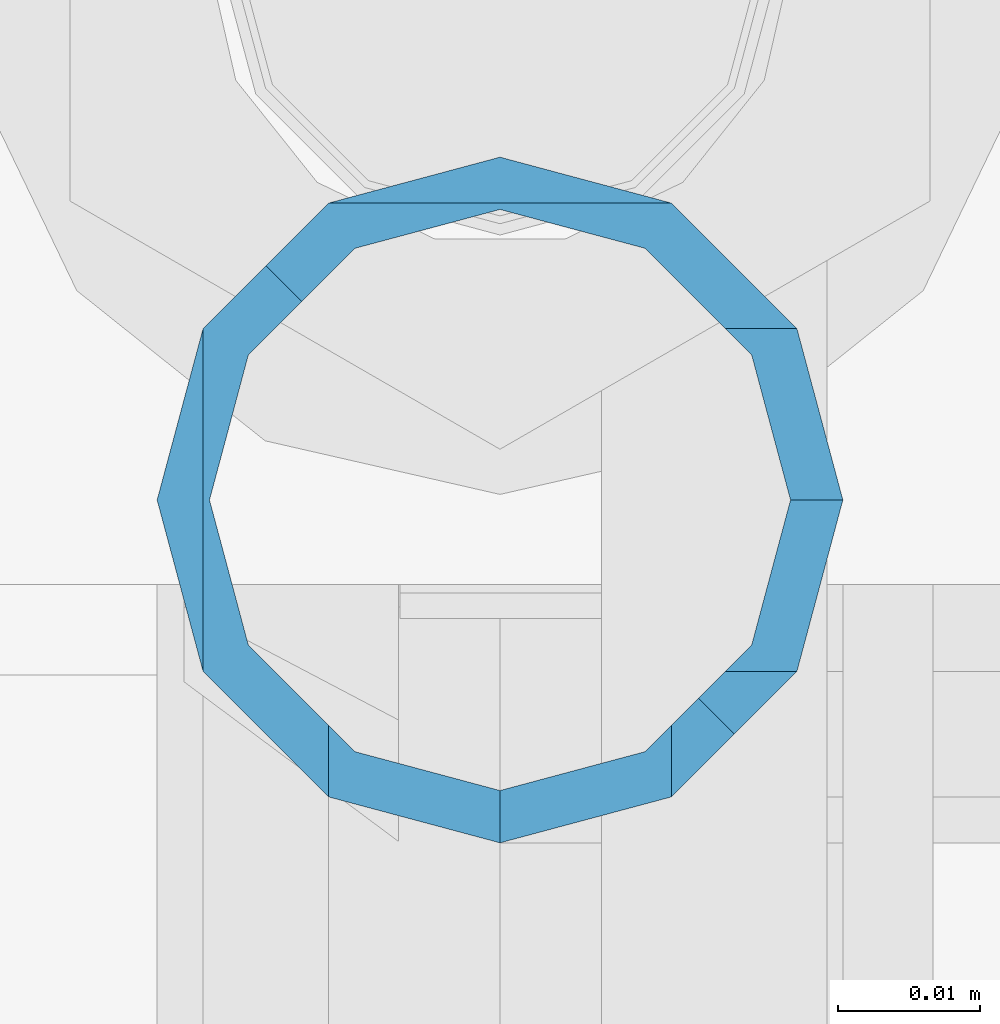
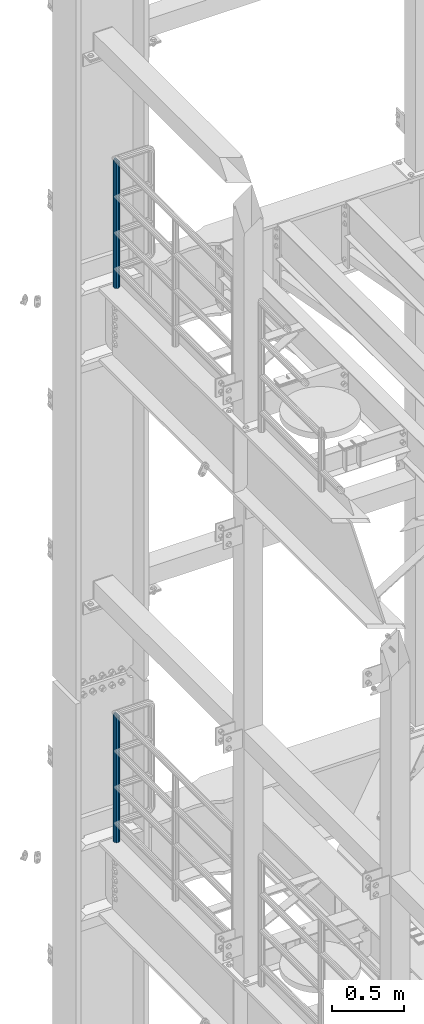
# One storey, part 747 of 1876: 2 columns, 2 elements without a shape of their own.
"""IFC2X3 building model written with IfcOpenShell, lengths in millimetres."""

from ifc_helpers import new_model, si_unit, frame, origin_with_axes, place, context, subcontext, project, spatial, faceted_brep, material, type_object, element, aggregate, save


model = new_model("IFC2X3")

# Units and contexts
model_context = context("Model", 3, precision=1e-05, world=origin_with_axes())
body_context = subcontext(model_context, "Body", "Model", "MODEL_VIEW")
ifc_project = project(units=[si_unit("LENGTHUNIT", "METRE", prefix="MILLI"), si_unit("AREAUNIT", "SQUARE_METRE"), si_unit("VOLUMEUNIT", "CUBIC_METRE"), si_unit("MASSUNIT", "GRAM", prefix="KILO"), si_unit("TIMEUNIT", "SECOND"), si_unit("PLANEANGLEUNIT", "RADIAN"), si_unit("SOLIDANGLEUNIT", "STERADIAN"), si_unit("THERMODYNAMICTEMPERATUREUNIT", "DEGREE_CELSIUS"), si_unit("LUMINOUSINTENSITYUNIT", "LUMEN")], contexts=[model_context])

# Site, building, storey
site_placement = place(None, origin_with_axes())
site = spatial("IfcSite", under=ifc_project, at=site_placement, CompositionType="ELEMENT")
building_placement = place(site_placement, origin_with_axes())
building = spatial("IfcBuilding", under=site, at=building_placement, Name="Undefined", CompositionType="ELEMENT")
storey_placement = place(building_placement, origin_with_axes())
storey = spatial("IfcBuildingStorey", under=building, at=storey_placement, Name="Undefined", CompositionType="ELEMENT", Elevation=0.0)

# Assembly, column
assembly_1_placement = place(storey_placement, origin_with_axes())
assembly_1 = element("IfcElementAssembly", 1, at=assembly_1_placement, inside=storey, Name="RAIL", AssemblyPlace="NOTDEFINED", PredefinedType="RIGID_FRAME")
ifc_material = material()
column_type = type_object("IfcColumnType", Name="PIPE1-1/2SCH40", PredefinedType="NOTDEFINED")
column_1_placement = place(assembly_1_placement, frame((-1.81898940354586e-12, 13499.7063, 17983.2), z_axis=(0.0, 1.0, 0.0), x_axis=(0.0, 0.0, 1.0)))
column_1 = element("IfcColumn", 2, at=column_1_placement, type_object=column_type, material=ifc_material, Name="POST", ObjectType="PIPE1-1/2SCH40", context=body_context, shape_type="Brep", body=[
    faceted_brep([(1076.325, -24.1300000000001, 0.0), (1064.25999999999, -20.8971929933186, -12.0649999999996), (1064.26, -20.8971929933184, 12.0649999999996), (1054.93437856882, 17.7076214311801, 10.2235000000001), (1052.195, 20.4470000000001, 0.0), (1052.195, 24.13, 0.0), (1055.42780700668, 20.8971929933185, 12.0649999999996), (1055.42780700668, 15.8661214311869, 12.0649999999932), (1055.42780700668, 15.8661214311742, -12.065000000006), (1055.42780700668, 20.8971929933185, -12.0649999999996), (1054.93437856882, 17.7076214311801, -10.2235000000001), (1057.32837749232, 13.9655704718316, -13.9655509593485), (1059.84391327712, 16.4811062541432, -16.4810867391752), (1055.42780700668, 12.0650000000001, -15.8661214311805), (1055.42780700667, 12.0649999999996, -20.8971929933186), (1054.93437856882, 10.2235000000001, -17.7076214311801), (1052.195, 0.0, -20.4470000000001), (1052.19499999999, 0.0, -24.1300000000001), (1055.42780700668, -12.0650000000001, -15.8661214311805), (1055.42780700667, -12.0649999999996, -20.8971929933186), (1054.93437856882, -10.2235000000001, -17.7076214311801), (1061.07042843786, -17.7076214311803, -10.2235000000001), (1063.80980700668, -20.4469999999999, 0.0), (1061.07042843786, -17.7076214311803, 10.2235000000001), (1057.32835795223, -13.9655509593467, 13.9655704718334), (1059.84389372957, -16.4810867391727, 16.4811062541457), (1076.325, 0.0, 24.1300000000001), (1064.26, -12.0650000000001, 20.8971929933186), (1064.26, 12.065, 20.8971929933186), (1061.07042843787, -10.2235000000001, 17.7076214311801), (1063.80980700669, 0.0, 20.4470000000001), (1061.07042843787, 10.2235000000001, 17.7076214311801), (0.0, -20.8971929933184, -12.0649999999996), (0.0, -12.0650000000001, -20.8971929933186), (-1.45519152283669e-11, 0.0, -24.130000000001), (0.0, 12.0650000000001, -20.8971929933186), (0.0, 20.8971929933184, -12.0649999999996), (0.0, 24.1299999999992, 0.0), (0.0, 20.8971929933184, 12.0649999999996), (0.0, 12.0650000000001, 20.8971929933186), (-1.45519152283669e-11, 0.0, 24.130000000001), (0.0, -20.8971929933184, 12.0649999999996), (0.0, -24.1299999999992, 0.0), (0.0, -12.0650000000001, 20.8971929933186), (0.0, -17.7076214311803, -10.2235000000001), (0.0, -10.2235000000001, -17.7076214311801), (-1.45519152283669e-11, 0.0, -20.4470000000001), (0.0, 10.2235000000001, -17.7076214311801), (0.0, 17.7076214311803, -10.2235000000001), (0.0, 20.4469999999999, 0.0), (0.0, 17.7076214311803, 10.2235000000001), (0.0, 10.2235000000001, 17.7076214311801), (-1.45519152283669e-11, 0.0, 20.4470000000001), (0.0, -10.2235000000001, 17.7076214311801), (0.0, -17.7076214311803, 10.2235000000001), (0.0, -20.4469999999999, 0.0)], [[[0, 1, 2]], [[3, 4, 5, 6, 7]], [[8, 9, 5, 4, 10]], [[9, 8, 11, 12]], [[12, 11, 13, 14]], [[15, 16, 17, 14, 13]], [[18, 19, 17, 16, 20]], [[2, 1, 19, 18, 21, 22, 23, 24, 25]], [[26, 27, 28]], [[25, 24, 29, 30, 31, 7, 6, 28, 27]], [[32, 33, 19, 1]], [[33, 34, 17, 19]], [[34, 35, 14, 17]], [[35, 36, 9, 12, 14]], [[36, 37, 5, 9]], [[37, 38, 6, 5]], [[38, 39, 28, 6]], [[39, 40, 26, 28]], [[41, 42, 0, 2]], [[43, 41, 2, 25, 27]], [[40, 43, 27, 26]], [[42, 32, 1, 0]], [[41, 43, 40, 39, 38, 37, 36, 35, 34, 33, 32, 42], [44, 45, 46, 47, 48, 49, 50, 51, 52, 53, 54, 55]], [[53, 52, 30, 29]], [[23, 54, 53, 29, 24]], [[55, 54, 23, 22]], [[44, 55, 22, 21]], [[20, 45, 44, 21, 18]], [[46, 45, 20, 16]], [[47, 46, 16, 15]], [[10, 48, 47, 15, 13, 11, 8]], [[49, 48, 10, 4]], [[50, 49, 4, 3]], [[51, 50, 3, 7, 31]], [[52, 51, 31, 30]]]),
])
aggregate(assembly_1, [column_1])

assembly_2_placement = place(storey_placement, origin_with_axes())
assembly_2 = element("IfcElementAssembly", 3, at=assembly_2_placement, inside=storey, Name="RAIL", AssemblyPlace="NOTDEFINED", PredefinedType="RIGID_FRAME")
column_2_placement = place(assembly_2_placement, frame((-1.81898940354586e-12, 13499.7063, 13309.6), z_axis=(0.0, 1.0, 0.0), x_axis=(0.0, 0.0, 1.0)))
column_2 = element("IfcColumn", 4, at=column_2_placement, type_object=column_type, material=ifc_material, Name="POST", ObjectType="PIPE1-1/2SCH40", context=body_context, shape_type="Brep", body=[
    faceted_brep([(1076.325, -24.1300000000001, 0.0), (1064.25999999999, -20.8971929933186, -12.0649999999996), (1064.26, -20.8971929933184, 12.0649999999996), (1054.93437856882, 17.7076214311801, 10.2235000000001), (1052.195, 20.4470000000001, 0.0), (1052.195, 24.13, 0.0), (1055.42780700668, 20.8971929933185, 12.0649999999996), (1055.42780700668, 15.8661214311869, 12.0649999999932), (1055.42780700668, 15.8661214311742, -12.065000000006), (1055.42780700668, 20.8971929933185, -12.0649999999996), (1054.93437856882, 17.7076214311801, -10.2235000000001), (1057.32837749232, 13.9655704718316, -13.9655509593485), (1059.84391327712, 16.4811062541432, -16.4810867391752), (1055.42780700668, 12.0650000000001, -15.8661214311805), (1055.42780700667, 12.0649999999996, -20.8971929933186), (1054.93437856882, 10.2235000000001, -17.7076214311801), (1052.195, 0.0, -20.4470000000001), (1052.19499999999, 0.0, -24.1300000000001), (1055.42780700668, -12.0650000000001, -15.8661214311805), (1055.42780700667, -12.0649999999996, -20.8971929933186), (1054.93437856882, -10.2235000000001, -17.7076214311801), (1061.07042843786, -17.7076214311803, -10.2235000000001), (1063.80980700668, -20.4469999999999, 0.0), (1061.07042843786, -17.7076214311803, 10.2235000000001), (1057.32835795223, -13.9655509593467, 13.9655704718334), (1059.84389372957, -16.4810867391727, 16.4811062541457), (1076.325, 0.0, 24.1300000000001), (1064.26, -12.0650000000001, 20.8971929933186), (1064.26, 12.065, 20.8971929933186), (1061.07042843787, -10.2235000000001, 17.7076214311801), (1063.80980700669, 0.0, 20.4470000000001), (1061.07042843787, 10.2235000000001, 17.7076214311801), (0.0, -20.8971929933184, -12.0649999999996), (0.0, -12.0650000000001, -20.8971929933186), (-1.45519152283669e-11, 0.0, -24.130000000001), (0.0, 12.0650000000001, -20.8971929933186), (0.0, 20.8971929933184, -12.0649999999996), (0.0, 24.1299999999992, 0.0), (0.0, 20.8971929933184, 12.0649999999996), (0.0, 12.0650000000001, 20.8971929933186), (-1.45519152283669e-11, 0.0, 24.130000000001), (0.0, -20.8971929933184, 12.0649999999996), (0.0, -24.1299999999992, 0.0), (0.0, -12.0650000000001, 20.8971929933186), (0.0, -17.7076214311803, -10.2235000000001), (0.0, -10.2235000000001, -17.7076214311801), (-1.45519152283669e-11, 0.0, -20.4470000000001), (0.0, 10.2235000000001, -17.7076214311801), (0.0, 17.7076214311803, -10.2235000000001), (0.0, 20.4469999999999, 0.0), (0.0, 17.7076214311803, 10.2235000000001), (0.0, 10.2235000000001, 17.7076214311801), (-1.45519152283669e-11, 0.0, 20.4470000000001), (0.0, -10.2235000000001, 17.7076214311801), (0.0, -17.7076214311803, 10.2235000000001), (0.0, -20.4469999999999, 0.0)], [[[0, 1, 2]], [[3, 4, 5, 6, 7]], [[8, 9, 5, 4, 10]], [[9, 8, 11, 12]], [[12, 11, 13, 14]], [[15, 16, 17, 14, 13]], [[18, 19, 17, 16, 20]], [[2, 1, 19, 18, 21, 22, 23, 24, 25]], [[26, 27, 28]], [[25, 24, 29, 30, 31, 7, 6, 28, 27]], [[32, 33, 19, 1]], [[33, 34, 17, 19]], [[34, 35, 14, 17]], [[35, 36, 9, 12, 14]], [[36, 37, 5, 9]], [[37, 38, 6, 5]], [[38, 39, 28, 6]], [[39, 40, 26, 28]], [[41, 42, 0, 2]], [[43, 41, 2, 25, 27]], [[40, 43, 27, 26]], [[42, 32, 1, 0]], [[41, 43, 40, 39, 38, 37, 36, 35, 34, 33, 32, 42], [44, 45, 46, 47, 48, 49, 50, 51, 52, 53, 54, 55]], [[53, 52, 30, 29]], [[23, 54, 53, 29, 24]], [[55, 54, 23, 22]], [[44, 55, 22, 21]], [[20, 45, 44, 21, 18]], [[46, 45, 20, 16]], [[47, 46, 16, 15]], [[10, 48, 47, 15, 13, 11, 8]], [[49, 48, 10, 4]], [[50, 49, 4, 3]], [[51, 50, 3, 7, 31]], [[52, 51, 31, 30]]]),
])
aggregate(assembly_2, [column_2])

save(model, "model.ifc")
